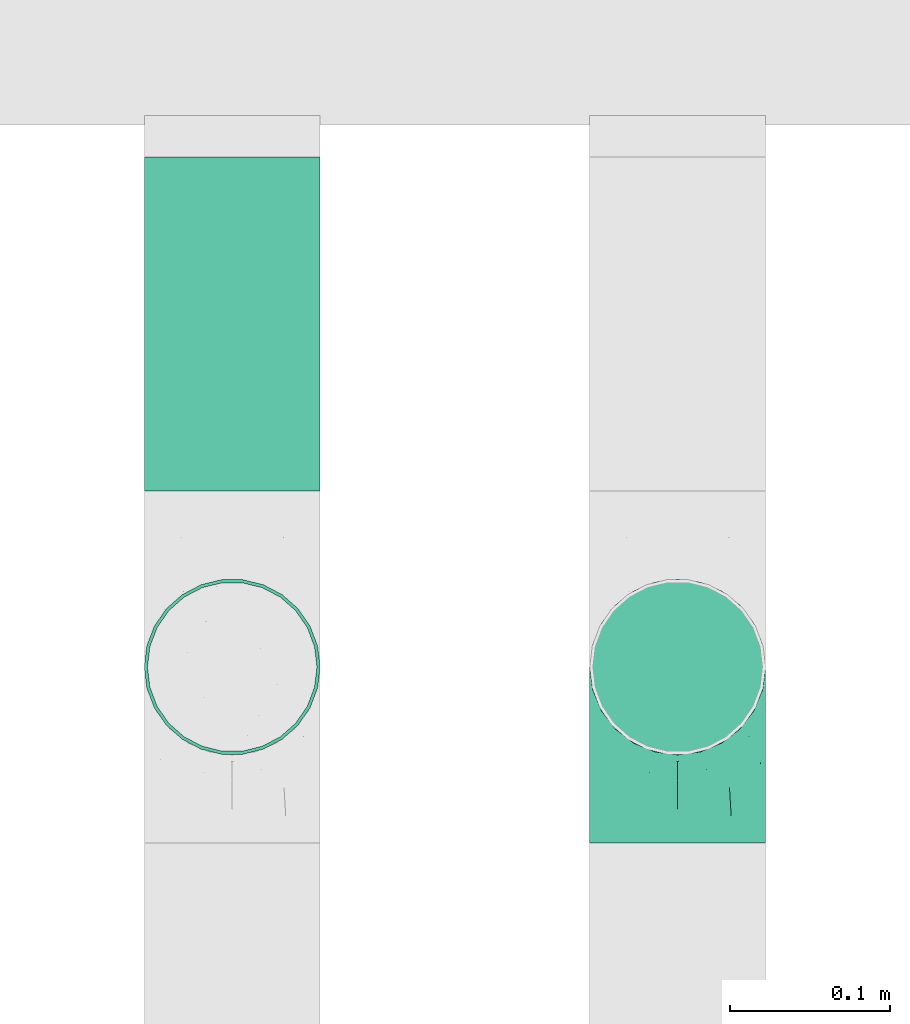
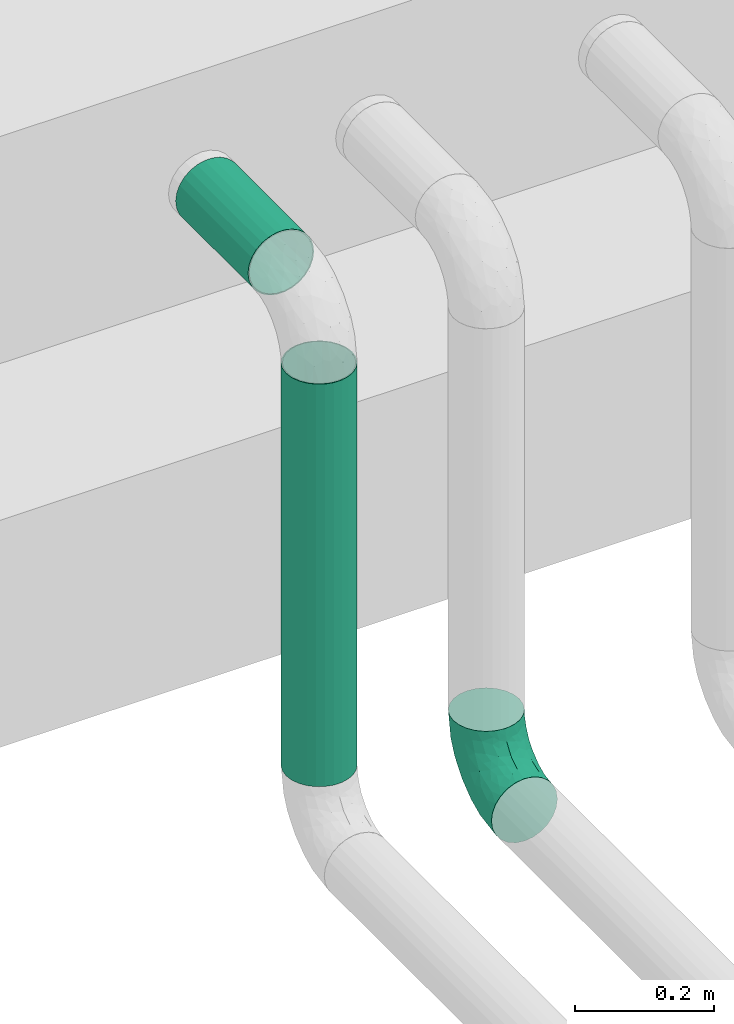
# One storey, part 23 of 91: 2 flow segments, 1 flow fitting.
"""IFC2X3 building model written with IfcOpenShell, lengths in millimetres."""

from ifc_helpers import new_model, entity, si_unit, converted_unit, derived_unit, direction, frame, origin_with_axes, origin_2d_with_axis, place, context, subcontext, project, spatial, hollow_circle, extrude, open_shell, surface_model, source, transform, mapped, material, layer, layer_set, layer_usage, type_object, element, save


model = new_model("IFC2X3")

# Units and contexts
model_context = context("Model", 3, precision=1e-05, world=origin_with_axes(), true_north=direction((0.0, 1.0)))
body_context = subcontext(model_context, "Body", "Model", "MODEL_VIEW")
ifc_project = project(units=[si_unit("AREAUNIT", "SQUARE_METRE"), si_unit("VOLUMEUNIT", "CUBIC_METRE", prefix="DECI"), si_unit("TIMEUNIT", "SECOND"), si_unit("THERMODYNAMICTEMPERATUREUNIT", "DEGREE_CELSIUS"), si_unit("PRESSUREUNIT", "PASCAL"), si_unit("MASSUNIT", "GRAM", prefix="KILO"), si_unit("LENGTHUNIT", "METRE", prefix="MILLI"), si_unit("POWERUNIT", "WATT"), si_unit("ELECTRICCURRENTUNIT", "AMPERE"), si_unit("ELECTRICVOLTAGEUNIT", "VOLT"), derived_unit("VOLUMETRICFLOWRATEUNIT", [(si_unit("VOLUMEUNIT", "CUBIC_METRE", prefix="DECI"), 1), (si_unit("TIMEUNIT", "SECOND"), -1)]), derived_unit("LINEARVELOCITYUNIT", [(si_unit("LENGTHUNIT", "METRE"), 1), (si_unit("TIMEUNIT", "SECOND"), -1)]), derived_unit("MASSDENSITYUNIT", [(si_unit("MASSUNIT", "GRAM", prefix="KILO"), 1), (si_unit("VOLUMEUNIT", "CUBIC_METRE"), -1)]), converted_unit("PLANEANGLEUNIT", "DEGREE", entity("IfcRatioMeasure", 0.01745), si_unit("PLANEANGLEUNIT", "RADIAN"), dimensions=[0, 0, 0, 0, 0, 0, 0])], contexts=[model_context])

# Site, building, storey
site_placement = place(None, origin_with_axes())
site = spatial("IfcSite", under=ifc_project, at=site_placement, CompositionType="ELEMENT")
building_placement = place(site_placement, origin_with_axes())
building = spatial("IfcBuilding", under=site, at=building_placement, Name="mc-building", CompositionType="ELEMENT")
storey_placement = place(building_placement, frame((0.0, 0.0, 8700.0), z_axis=(0.0, 0.0, 1.0), x_axis=(1.0, 0.0, 0.0)))
storey = spatial("IfcBuildingStorey", under=building, at=storey_placement, CompositionType="ELEMENT", Elevation=8700.0)

# Flow segments
ifc_material = material(Name="FZ1")
ifc_layer = layer(ifc_material, 0.0)
ifc_layer_set = layer_set([ifc_layer], Name="FZ1")
ifc_layer_usage = layer_usage(ifc_layer_set, "AXIS1", "POSITIVE", 0.0)
duct_segment_type = type_object("IfcDuctSegmentType", PredefinedType="RIGIDSEGMENT")
shared_shape_1 = source(origin_with_axes(), body_context, "Body", "SweptSolid", [
    extrude(hollow_circle(Radius=55.0, WallThickness=2.0, at=origin_2d_with_axis()), frame((0.0, 0.0, 0.0), z_axis=(1.0, 0.0, 0.0), x_axis=(0.0, 1.0, 0.0)), (0.0, 0.0, 1.0), 709.0),
])
flow_segment_1_placement = place(storey_placement, frame((15517.82156, 2612.35324, 1234.0), z_axis=(0.0, 1.0, 0.0), x_axis=(0.0, 0.0, -1.0)))
element("IfcFlowSegment", 1, at=flow_segment_1_placement, inside=storey, type_object=duct_segment_type, material=ifc_layer_usage, context=body_context, shape_type="MappedRepresentation", body=[
    mapped(shared_shape_1, transform((0.0, 0.0, 0.0), scale=1.0)),
])
shared_shape_2 = source(origin_with_axes(), body_context, "Body", "SweptSolid", [
    extrude(hollow_circle(Radius=55.0, WallThickness=2.0, at=origin_2d_with_axis()), frame((0.0, 0.0, 0.0), z_axis=(1.0, 0.0, 0.0), x_axis=(0.0, 1.0, 0.0)), (0.0, 0.0, 1.0), 208.9),
])
flow_segment_2_placement = place(storey_placement, frame((15517.82156, 2931.20513, 1344.0), z_axis=(0.0, 0.0, 1.0), x_axis=(0.0, -1.0, 0.0)))
element("IfcFlowSegment", 2, at=flow_segment_2_placement, inside=storey, type_object=duct_segment_type, material=ifc_layer_usage, context=body_context, shape_type="MappedRepresentation", body=[
    mapped(shared_shape_2, transform((0.0, 0.0, 0.0), scale=1.0, scale2=1.0, scale3=1.0, uniform=False)),
])

# Flow fitting
duct_fitting_type = type_object("IfcDuctFittingType", Name="BU", PredefinedType="BEND")
shared_shape_3 = source(origin_with_axes(), body_context, "Body", "SurfaceModel", [
    surface_model("IfcShellBasedSurfaceModel", [(-110.0, 0.0, -55.0), (-110.0, -14.23505, -53.12592), (-110.0, 14.23505, -53.12592), (-110.0, 53.12592, 14.23505), (-110.0, 27.5, -47.63139), (-110.0, 38.89087, -38.89087), (-110.0, -55.0, 0.0), (-110.0, -53.12592, 14.23505), (-110.0, -38.89087, -38.89087), (-110.0, -27.5, -47.63139), (-110.0, -53.12592, -14.23505), (-110.0, -47.63139, -27.5), (-110.0, -14.23505, 53.12592), (-110.0, 14.23505, 53.12592), (-110.0, 27.5, 47.63139), (-110.0, -47.63139, 27.5), (-110.0, -38.89087, 38.89087), (-110.0, -27.5, 47.63139), (-110.0, 0.0, 55.0), (-110.0, 55.0, 0.0), (-110.0, 53.12592, -14.23505), (-110.0, 47.63139, -27.5), (-110.0, 47.63139, 27.5), (-110.0, 38.89087, 38.89087), (-14.23505, 110.0, -53.12592), (-55.0, 110.0, 0.0), (0.0, 110.0, -55.0), (-27.5, 110.0, -47.63139), (-38.89087, 110.0, -38.89087), (-47.63139, 110.0, -27.5), (38.89087, 110.0, -38.89087), (53.12592, 110.0, 14.23505), (27.5, 110.0, -47.63139), (14.23505, 110.0, -53.12592), (47.63139, 110.0, -27.5), (53.12592, 110.0, -14.23505), (55.0, 110.0, 0.0), (-53.12592, 110.0, -14.23505), (-53.12592, 110.0, 14.23505), (-47.63139, 110.0, 27.5), (-38.89087, 110.0, 38.89087), (-27.5, 110.0, 47.63139), (0.0, 110.0, 55.0), (-14.23505, 110.0, 53.12592), (38.89087, 110.0, 38.89087), (47.63139, 110.0, 27.5), (27.5, 110.0, 47.63139), (14.23505, 110.0, 53.12592), (-64.21732, 48.68956, 43.63444), (-76.6405, 38.18013, 45.55988), (-60.44912, 32.56953, 51.94617), (-76.00813, 5.38378, 55.0), (-90.15553, 11.94394, 54.09138), (-78.5998, 26.77405, 50.81338), (-70.18771, 18.55163, 54.03432), (-75.55424, 54.2118, 32.41257), (-93.27622, 45.77614, 33.48188), (-96.12334, 22.13664, 50.81337), (-21.00813, 45.34362, 55.0), (-18.36258, 70.48427, 54.04484), (-32.04182, 59.64019, 52.24446), (-63.88653, 74.77858, 17.99134), (-74.66383, 63.08407, 19.92123), (-63.60674, 66.07878, 29.97482), (-99.597, 52.72185, 18.52927), (-93.11138, 56.59448, 10.50359), (-98.21577, 57.34403, 0.0), (-53.42855, 92.60092, 21.04759), (-88.54852, 54.8376, 21.04759), (-11.86161, 90.23965, 54.10313), (-5.38378, 76.00813, 55.0), (-57.34403, 98.21577, 0.0), (-56.64619, 93.12774, 10.22088), (-45.34362, 21.00813, 55.0), (-44.60838, 44.60838, 52.13415), (-92.68484, 35.46673, 43.63443), (-22.25266, 95.40765, 50.81337), (-35.97783, 90.61597, 43.63443), (-43.70931, 69.58671, 44.47149), (-27.23711, 77.39884, 50.81337), (-57.2828, 79.3123, 24.9774), (-58.67786, 84.31125, 16.04456), (-82.93277, 60.36161, 12.91784), (-49.88337, 54.51816, 47.224), (-74.57753, 66.83759, 9.55742), (-45.35812, 94.97281, 33.48188), (-59.18663, 88.95241, 0.0), (-51.517, 78.6292, 33.48188), (-65.14788, 80.03077, 0.0), (-56.45322, 62.06476, 39.63545), (-88.95241, 59.18663, 0.0), (-71.10913, 71.10913, 0.0), (-80.03077, 65.14788, 0.0), (-94.9309, 45.36788, -33.48188), (-93.11358, 56.60141, -10.46614), (-99.64997, 52.79499, -18.30015), (-90.20425, 36.08686, -43.63443), (-79.99933, 46.56772, -37.92748), (-76.00813, 5.38378, -55.0), (-72.75364, 19.68651, -53.60527), (-45.34362, 21.00813, -55.0), (-21.91957, 65.12078, -53.85897), (-5.38378, 76.00813, -55.0), (-21.00813, 45.34362, -55.0), (-35.41876, 92.89265, -43.63443), (-91.10309, 11.02766, -54.21832), (-45.77614, 93.27622, -33.48188), (-90.50474, 23.21022, -50.81337), (-70.92854, 33.31794, -49.51754), (-78.52933, 63.35627, -11.73997), (-24.91508, 84.05606, -50.81337), (-88.78941, 54.74452, -21.04759), (-69.59921, 57.34866, -33.48187), (-73.36422, 62.46673, -22.94182), (-63.49062, 67.59111, -28.46929), (-56.59448, 93.11138, -10.50359), (-54.8376, 88.54852, -21.04759), (-54.10679, 75.85581, -32.31867), (-57.75956, 31.09612, -52.80882), (-52.72185, 99.597, -18.52927), (-12.62913, 89.46304, -53.99097), (-34.46825, 66.46123, -50.04329), (-43.9837, 43.9837, -52.42279), (-65.78527, 72.58348, -17.68796), (-70.34468, 43.65295, -44.21951), (-57.47001, 51.99467, -44.91465), (-60.72547, 82.29174, -12.88567), (-42.34915, 74.24548, -43.63444), (-57.25194, 63.5016, -38.08211), (-80.95344, 53.56991, -29.32027), (-52.32891, 4.55257, -54.0482), (32.52942, 47.13398, -30.48571), (14.88266, 20.92917, -33.7947), (14.95561, 36.05775, -42.26543), (30.24048, 70.09027, -41.7461), (19.3559, 65.35825, -48.00507), (-70.35075, -46.44478, -19.5952), (-47.13398, -32.52942, -30.48571), (-28.49299, -30.5778, -16.4009), (-4.55257, 52.32891, -54.0482), (-22.4954, 22.4954, -53.25347), (-75.47368, -11.22546, -52.60718), (-81.32209, -51.5606, -9.98467), (-80.81763, -41.84862, -32.14655), (-70.09027, -30.24048, -41.7461), (-36.05774, -14.95561, -42.26543), (-9.15831, -10.852, -27.8997), (-65.35825, -19.3559, -48.00507), (11.22546, 75.47368, -52.60718), (3.94376, 43.9333, -50.53315), (-13.39742, 13.39743, -48.13058), (-43.9333, -3.94376, -50.53315), (49.37776, 67.29486, 0.0), (41.8609, 47.82256, -9.92641), (50.20582, 74.51695, -9.9731), (18.93131, 11.7156, -17.56239), (-27.5, -32.89419, 0.0), (-1.23348, -12.25375, -12.18106), (41.84862, 80.81763, -32.14655), (35.70604, 41.31408, -20.38235), (46.44478, 70.35075, -19.5952), (32.89419, 27.5, 0.0), (6.67262, -6.67262, 0.0), (-67.29486, -49.37776, 0.0), (-50.36265, -42.95545, -9.51562), (-5.47251, 5.47251, -39.92906), (-70.35075, -46.44478, 19.5952), (-74.51695, -50.20582, 9.9731), (-41.31407, -35.70604, 20.38235), (-47.13398, -32.52942, 30.48571), (-80.81763, -41.84862, 32.14655), (-4.55257, 52.32891, 54.0482), (11.22546, 75.47368, 52.60718), (-43.9333, -3.94376, 50.53315), (-65.35825, -19.3559, 48.00507), (-36.05774, -14.95561, 42.26543), (-70.09027, -30.24048, 41.7461), (-11.7156, -18.93131, 17.56239), (30.5778, 28.49299, 16.4009), (12.25375, 1.23348, 12.18106), (51.5606, 81.32209, 9.98467), (42.95545, 50.36265, 9.51562), (-75.47368, -11.22546, 52.60718), (-52.32891, 4.55257, 54.0482), (3.94376, 43.9333, 50.53315), (-22.4954, 22.4954, 53.25347), (-13.39742, 13.39743, 48.13058), (10.852, 9.15831, 27.8997), (-20.92916, -14.88266, 33.79469), (-47.82256, -41.8609, 9.92641), (32.52942, 47.13398, 30.48571), (46.44478, 70.35075, 19.5952), (41.84862, 80.81763, 32.14655), (30.24048, 70.09027, 41.7461), (19.3559, 65.35825, 48.00507), (14.95561, 36.05775, 42.26543), (-5.47251, 5.47251, 39.92906)], [open_shell([[[0, 1, 2]], [[2, 3, 4]], [[4, 3, 5]], [[2, 6, 7]], [[8, 6, 9]], [[1, 9, 6]], [[10, 6, 11]], [[8, 11, 6]], [[6, 2, 1]], [[12, 13, 14]], [[15, 2, 7]], [[16, 17, 2]], [[2, 17, 12]], [[12, 18, 13]], [[19, 20, 3]], [[5, 3, 21]], [[20, 21, 3]], [[22, 3, 2]], [[23, 22, 2]], [[12, 14, 2]], [[2, 14, 23]], [[15, 16, 2]], [[24, 25, 26]], [[27, 25, 24]], [[25, 28, 29]], [[28, 25, 27]], [[30, 26, 31]], [[26, 30, 32]], [[32, 33, 26]], [[34, 31, 35]], [[31, 34, 30]], [[35, 31, 36]], [[29, 37, 25]], [[38, 39, 26]], [[39, 40, 26]], [[41, 42, 40]], [[42, 26, 40]], [[42, 41, 43]], [[26, 44, 45]], [[31, 26, 45]], [[26, 46, 44]], [[47, 46, 26]], [[42, 47, 26]], [[25, 38, 26]], [[48, 49, 50]], [[18, 51, 52]], [[53, 54, 50]], [[55, 56, 49]], [[56, 22, 23]], [[13, 57, 14]], [[58, 59, 60]], [[61, 62, 63]], [[3, 64, 65]], [[53, 52, 54]], [[3, 65, 66]], [[67, 39, 38]], [[56, 68, 64]], [[65, 64, 68]], [[69, 59, 70]], [[38, 71, 72]], [[73, 58, 74]], [[75, 49, 56]], [[76, 69, 43]], [[53, 57, 52]], [[77, 78, 79]], [[41, 76, 43]], [[43, 69, 42]], [[55, 68, 56]], [[23, 14, 75]], [[76, 77, 79]], [[80, 67, 81]], [[62, 82, 68]], [[60, 78, 83]], [[62, 84, 82]], [[85, 77, 40]], [[81, 67, 72]], [[86, 72, 71]], [[87, 85, 67]], [[61, 81, 88]], [[77, 41, 40]], [[78, 77, 87]], [[23, 75, 56]], [[83, 89, 48]], [[85, 40, 39]], [[62, 68, 55]], [[89, 87, 63]], [[83, 48, 50]], [[57, 75, 14]], [[49, 75, 53]], [[67, 85, 39]], [[87, 77, 85]], [[63, 62, 55]], [[89, 55, 48]], [[80, 63, 87]], [[66, 65, 90]], [[66, 19, 3]], [[84, 91, 92]], [[92, 90, 82]], [[65, 82, 90]], [[61, 84, 62]], [[92, 82, 84]], [[68, 82, 65]], [[3, 22, 64]], [[56, 64, 22]], [[38, 25, 71]], [[81, 72, 86]], [[38, 72, 67]], [[91, 61, 88]], [[80, 81, 61]], [[63, 80, 61]], [[67, 80, 87]], [[77, 76, 41]], [[79, 59, 69]], [[79, 69, 76]], [[42, 69, 70]], [[60, 59, 79]], [[58, 70, 59]], [[78, 60, 79]], [[58, 60, 74]], [[52, 57, 13]], [[75, 57, 53]], [[18, 52, 13]], [[52, 51, 54]], [[51, 73, 54]], [[50, 73, 74]], [[73, 50, 54]], [[50, 74, 83]], [[60, 83, 74]], [[89, 83, 78]], [[87, 89, 78]], [[55, 89, 63]], [[50, 49, 53]], [[55, 49, 48]], [[81, 86, 88]], [[91, 84, 61]], [[5, 21, 93]], [[90, 94, 66]], [[20, 94, 95]], [[96, 93, 97]], [[98, 99, 100]], [[96, 4, 5]], [[101, 102, 103]], [[28, 27, 104]], [[2, 105, 0]], [[104, 106, 28]], [[99, 105, 107]], [[108, 107, 96]], [[90, 109, 94]], [[107, 2, 4]], [[20, 66, 94]], [[27, 24, 110]], [[109, 111, 94]], [[112, 113, 114]], [[37, 115, 71]], [[116, 106, 117]], [[99, 118, 100]], [[116, 115, 119]], [[37, 119, 115]], [[24, 120, 110]], [[121, 110, 101]], [[119, 106, 116]], [[101, 110, 120]], [[122, 103, 100]], [[117, 123, 116]], [[124, 125, 108]], [[115, 116, 126]], [[106, 29, 28]], [[26, 102, 120]], [[127, 104, 110]], [[97, 124, 96]], [[125, 122, 118]], [[128, 127, 125]], [[96, 5, 93]], [[115, 126, 86]], [[117, 106, 127]], [[111, 113, 129]], [[95, 93, 21]], [[97, 129, 112]], [[110, 104, 27]], [[106, 104, 127]], [[96, 107, 4]], [[99, 107, 108]], [[99, 108, 118]], [[105, 99, 98]], [[112, 114, 128]], [[121, 125, 127]], [[20, 19, 66]], [[109, 90, 92]], [[94, 111, 95]], [[91, 123, 109]], [[129, 113, 112]], [[93, 95, 111]], [[21, 20, 95]], [[71, 115, 86]], [[71, 25, 37]], [[123, 91, 88]], [[126, 116, 123]], [[123, 88, 126]], [[86, 126, 88]], [[37, 29, 119]], [[106, 119, 29]], [[129, 93, 111]], [[124, 112, 125]], [[0, 105, 98]], [[107, 105, 2]], [[125, 118, 108]], [[100, 118, 122]], [[93, 129, 97]], [[113, 111, 109]], [[109, 123, 113]], [[114, 123, 117]], [[123, 114, 113]], [[128, 114, 117]], [[127, 128, 117]], [[112, 128, 125]], [[103, 122, 101]], [[110, 121, 127]], [[101, 122, 121]], [[125, 121, 122]], [[26, 120, 24]], [[101, 120, 102]], [[96, 124, 108]], [[92, 91, 109]], [[112, 124, 97]], [[100, 130, 98]], [[131, 132, 133]], [[32, 134, 135]], [[136, 137, 138]], [[139, 140, 103]], [[98, 141, 0]], [[142, 10, 136]], [[143, 144, 137]], [[6, 10, 142]], [[137, 145, 146]], [[144, 147, 145]], [[143, 136, 11]], [[11, 136, 10]], [[8, 143, 11]], [[148, 149, 139]], [[8, 9, 144]], [[9, 1, 147]], [[130, 141, 98]], [[103, 140, 100]], [[148, 135, 149]], [[150, 151, 140]], [[152, 153, 154]], [[130, 140, 151]], [[148, 26, 33]], [[147, 1, 141]], [[155, 146, 132]], [[156, 138, 157]], [[134, 30, 158]], [[150, 140, 149]], [[158, 30, 34]], [[30, 134, 32]], [[153, 159, 160]], [[131, 160, 159]], [[144, 145, 137]], [[36, 152, 154]], [[146, 138, 137]], [[155, 161, 162]], [[158, 160, 131]], [[133, 149, 135]], [[156, 163, 164]], [[163, 142, 164]], [[139, 103, 102]], [[153, 152, 161]], [[34, 35, 160]], [[162, 157, 155]], [[132, 165, 133]], [[157, 146, 155]], [[140, 130, 100]], [[141, 130, 151]], [[141, 151, 147]], [[141, 1, 0]], [[102, 26, 148]], [[140, 139, 149]], [[102, 148, 139]], [[135, 33, 32]], [[151, 150, 145]], [[9, 147, 144]], [[151, 145, 147]], [[145, 165, 146]], [[135, 148, 33]], [[133, 135, 134]], [[131, 133, 134]], [[133, 165, 150]], [[133, 150, 149]], [[145, 150, 165]], [[132, 131, 159]], [[146, 165, 132]], [[160, 158, 34]], [[134, 158, 131]], [[144, 143, 8]], [[136, 143, 137]], [[155, 153, 161]], [[154, 153, 160]], [[153, 155, 159]], [[132, 159, 155]], [[160, 35, 154]], [[36, 154, 35]], [[164, 136, 138]], [[6, 142, 163]], [[136, 164, 142]], [[156, 164, 138]], [[156, 157, 162]], [[146, 157, 138]], [[15, 7, 166]], [[6, 163, 167]], [[168, 169, 166]], [[166, 169, 170]], [[171, 172, 70]], [[173, 174, 175]], [[17, 176, 174]], [[177, 156, 162]], [[176, 16, 170]], [[170, 16, 15]], [[161, 178, 179]], [[152, 180, 181]], [[182, 173, 183]], [[18, 12, 182]], [[184, 185, 186]], [[183, 185, 73]], [[183, 73, 51]], [[177, 187, 188]], [[189, 168, 166]], [[187, 178, 190]], [[16, 176, 17]], [[161, 152, 181]], [[45, 191, 31]], [[45, 44, 192]], [[192, 191, 45]], [[180, 36, 31]], [[193, 194, 195]], [[46, 47, 194]], [[193, 195, 190]], [[193, 44, 46]], [[172, 42, 70]], [[185, 58, 73]], [[189, 163, 156]], [[163, 189, 167]], [[70, 58, 171]], [[184, 171, 185]], [[169, 188, 175]], [[180, 31, 191]], [[192, 193, 190]], [[191, 190, 178]], [[182, 174, 173]], [[194, 47, 172]], [[190, 195, 187]], [[186, 185, 173]], [[162, 179, 177]], [[188, 196, 175]], [[179, 187, 177]], [[185, 171, 58]], [[172, 171, 184]], [[172, 184, 194]], [[172, 47, 42]], [[51, 18, 182]], [[185, 183, 173]], [[51, 182, 183]], [[174, 12, 17]], [[184, 186, 195]], [[46, 194, 193]], [[184, 195, 194]], [[195, 196, 187]], [[174, 182, 12]], [[175, 174, 176]], [[169, 175, 176]], [[175, 196, 186]], [[175, 186, 173]], [[195, 186, 196]], [[188, 169, 168]], [[187, 196, 188]], [[166, 170, 15]], [[176, 170, 169]], [[193, 192, 44]], [[191, 192, 190]], [[177, 189, 156]], [[167, 189, 166]], [[189, 177, 168]], [[188, 168, 177]], [[166, 7, 167]], [[6, 167, 7]], [[181, 191, 178]], [[36, 180, 152]], [[191, 181, 180]], [[161, 181, 178]], [[161, 179, 162]], [[187, 179, 178]]])]),
])
flow_fitting_placement = place(storey_placement, frame((15796.4103, 2612.35324, 415.0), z_axis=(1.0, 0.0, 0.0), x_axis=(0.0, 1.0, 0.0)))
element("IfcFlowFitting", 3, at=flow_fitting_placement, inside=storey, type_object=duct_fitting_type, Name="BU", context=body_context, shape_type="MappedRepresentation", body=[
    mapped(shared_shape_3, transform((0.0, 0.0, 0.0), scale=1.0)),
])

save(model, "model.ifc")
